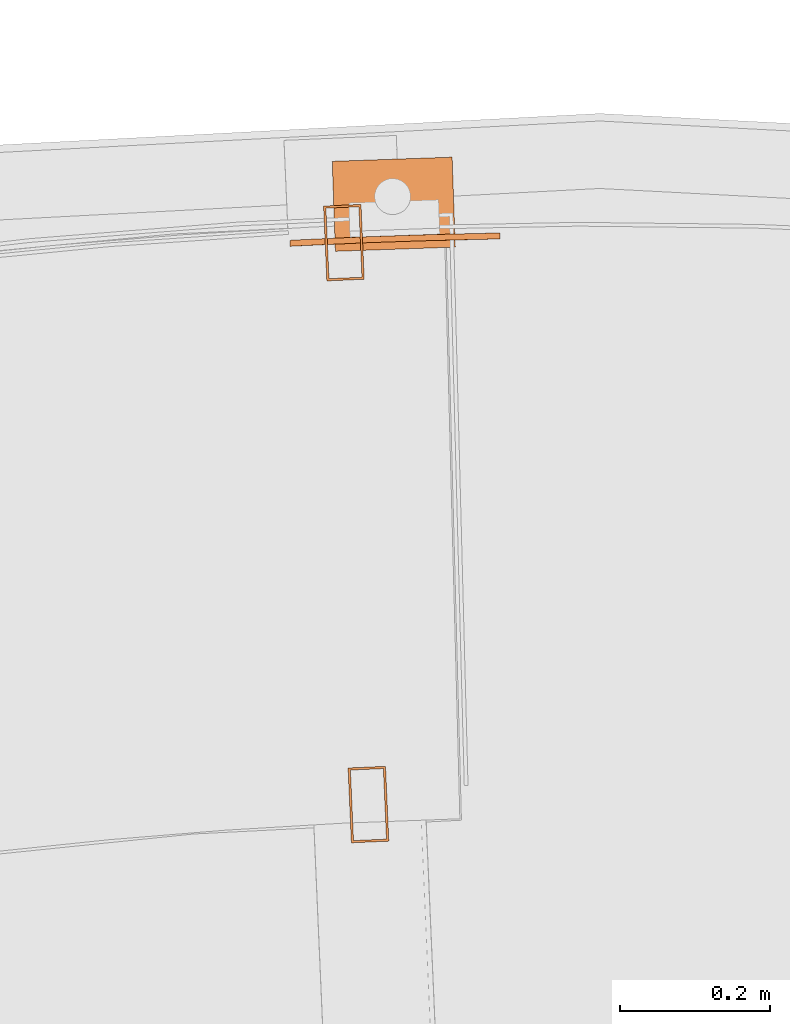
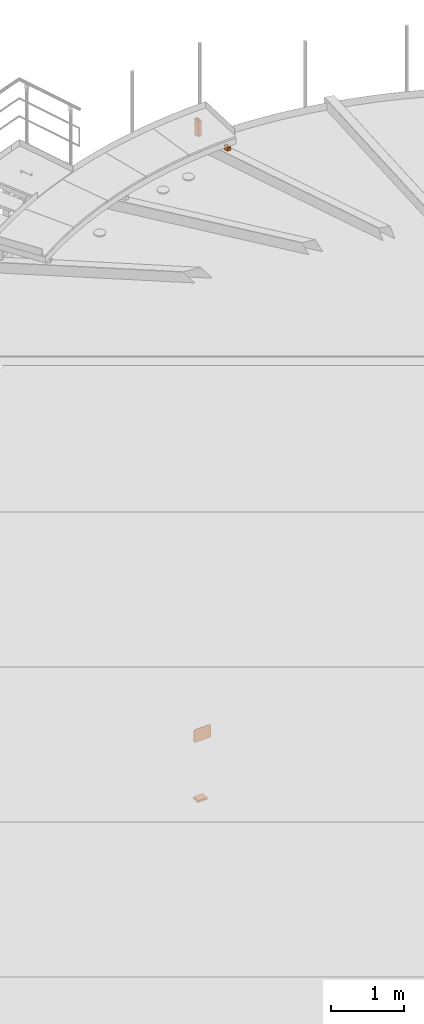
# One storey, part 92 of 126: 4 proxies.
"""IFC2X3 building model written with IfcOpenShell, lengths in millimetres."""

from ifc_helpers import new_model, si_unit, origin, origin_with_axes, place, context, project, spatial, faceted_brep, material, element, save


model = new_model("IFC2X3")

# Units and contexts
context_of_model_1 = context(None, 3, precision=0.1, world=origin())
context_of_model_2 = context(None, 3, precision=0.1, world=origin())
ifc_project = project(units=[si_unit("LENGTHUNIT", "METRE", prefix="MILLI"), si_unit("AREAUNIT", "SQUARE_METRE", prefix="CENTI"), si_unit("VOLUMEUNIT", "CUBIC_METRE", prefix="CENTI"), si_unit("MASSUNIT", "GRAM", prefix="KILO")], contexts=[context_of_model_1, context_of_model_2])

# Site, building, storey
site_placement = place(None, origin_with_axes())
site = spatial("IfcSite", under=ifc_project, at=site_placement, CompositionType="ELEMENT")
building_placement = place(site_placement, origin_with_axes())
building = spatial("IfcBuilding", under=site, at=building_placement, CompositionType="ELEMENT")
storey_placement = place(building_placement, origin_with_axes())
storey = spatial("IfcBuildingStorey", under=building, at=storey_placement, CompositionType="ELEMENT")

# Proxies
ifc_material = material(Name="STAHL")
proxy_1_placement = place(storey_placement, origin_with_axes())
element("IfcBuildingElementProxy", 1, at=proxy_1_placement, inside=storey, material=ifc_material, Name="profile", context=context_of_model_2, shape_type="Brep", body=[
    faceted_brep([(7859.1, 15822.4, 704.8), (7863.4, 15822.5, 701.2), (7863.2, 15830.5, 701.2), (7858.5, 15830.4, 705.0), (7854.1, 15822.3, 707.5), (7853.0, 15830.3, 707.9), (7848.1, 15822.2, 709.4), (7847.5, 15830.2, 709.5), (7616.6, 15814.1, 709.5), (7622.2, 15814.4, 710.0), (7695.5, 15817.7, 710.0), (7768.8, 15820.2, 710.0), (7842.1, 15822.1, 710.0), (7842.0, 15830.1, 710.0), (7768.6, 15828.2, 710.0), (7695.1, 15825.7, 710.0), (7621.7, 15822.4, 710.0), (7615.8, 15822.1, 709.4), (7597.4, 15813.2, 696.9), (7601.0, 15813.3, 701.2), (7600.6, 15821.3, 701.2), (7596.8, 15821.1, 696.5), (7594.7, 15813.0, 691.9), (7593.9, 15821.0, 691.0), (7592.8, 15812.9, 686.0), (7592.3, 15820.9, 685.5), (7592.2, 15812.9, 680.0), (7591.8, 15820.9, 680.0), (7591.8, 15820.9, 520.0), (7592.4, 15820.9, 514.0), (7592.7, 15812.9, 514.5), (7592.2, 15812.9, 520.0), (7858.9, 15830.4, 495.2), (7863.2, 15830.5, 498.8), (7863.4, 15822.5, 498.8), (7858.7, 15822.4, 495.0), (7853.9, 15830.3, 492.5), (7853.2, 15822.3, 492.1), (7848.0, 15830.2, 490.6), (7847.7, 15822.2, 490.5), (7616.2, 15814.1, 490.6), (7616.2, 15822.1, 490.5), (7621.7, 15822.4, 490.0), (7695.1, 15825.7, 490.0), (7768.6, 15828.2, 490.0), (7842.0, 15830.1, 490.0), (7842.1, 15822.1, 490.0), (7768.8, 15820.2, 490.0), (7695.5, 15817.7, 490.0), (7622.2, 15814.4, 490.0), (7597.0, 15821.1, 503.1), (7600.6, 15821.3, 498.8), (7601.0, 15813.3, 498.8), (7597.2, 15813.1, 503.5), (7594.3, 15821.0, 508.1), (7594.3, 15813.0, 509.0), (7610.7, 15821.9, 492.1), (7610.3, 15813.8, 492.5), (7605.2, 15821.6, 495.0), (7605.3, 15813.6, 495.2), (7871.5, 15822.7, 514.0), (7871.5, 15830.7, 514.5), (7872.0, 15830.7, 520.0), (7872.0, 15830.7, 680.0), (7871.4, 15830.6, 686.0), (7871.6, 15822.7, 685.5), (7872.1, 15822.7, 680.0), (7872.1, 15822.7, 520.0), (7869.9, 15830.6, 509.0), (7869.7, 15822.6, 508.1), (7867.0, 15830.6, 503.5), (7866.9, 15822.6, 503.1), (7611.1, 15813.9, 707.9), (7609.8, 15821.8, 707.5), (7605.6, 15813.6, 705.0), (7604.8, 15821.6, 704.8), (7870.0, 15822.6, 691.0), (7869.5, 15830.6, 691.9), (7867.2, 15822.6, 696.5), (7866.8, 15830.6, 696.9)], [[[0, 1, 2, 3]], [[4, 0, 3, 5]], [[6, 4, 5, 7]], [[8, 9, 10, 11, 12, 6, 7, 13, 14, 15, 16, 17]], [[18, 19, 20, 21]], [[22, 18, 21, 23]], [[24, 22, 23, 25]], [[26, 24, 25, 27, 28, 29, 30, 31]], [[32, 33, 34, 35]], [[36, 32, 35, 37]], [[38, 36, 37, 39]], [[40, 41, 42, 43, 44, 45, 38, 39, 46, 47, 48, 49]], [[50, 51, 52, 53]], [[54, 50, 53, 55]], [[29, 54, 55, 30]], [[56, 41, 40, 57]], [[58, 56, 57, 59]], [[51, 58, 59, 52]], [[60, 61, 62, 63, 64, 65, 66, 67]], [[68, 61, 60, 69]], [[70, 68, 69, 71]], [[33, 70, 71, 34]], [[72, 8, 17, 73]], [[74, 72, 73, 75]], [[19, 74, 75, 20]], [[76, 65, 64, 77]], [[78, 76, 77, 79]], [[1, 78, 79, 2]], [[26, 31, 30, 55, 53, 52, 59, 57, 40, 49, 48, 47, 46, 39, 37, 35, 34, 71, 69, 60, 67, 66, 65, 76, 78, 1, 0, 4, 6, 12, 11, 10, 9, 8, 72, 74, 19, 18, 22, 24]], [[28, 27, 25, 23, 21, 20, 75, 73, 17, 16, 15, 14, 13, 7, 5, 3, 2, 79, 77, 64, 63, 62, 61, 68, 70, 33, 32, 36, 38, 45, 44, 43, 42, 41, 56, 58, 51, 50, 54, 29]]]),
])
proxy_2_placement = place(storey_placement, origin_with_axes())
element("IfcBuildingElementProxy", 2, at=proxy_2_placement, inside=storey, material=ifc_material, Name="profile", context=context_of_model_2, shape_type="Brep", body=[
    faceted_brep([(7652.5, 15806.2, -530.0), (7648.3, 15926.2, -530.0), (7808.2, 15931.8, -530.0), (7812.4, 15811.8, -530.0), (7648.3, 15926.2, -500.0), (7808.2, 15931.8, -500.0), (7652.5, 15806.2, -500.0), (7812.4, 15811.8, -500.0)], [[[0, 1, 2, 3]], [[1, 4, 5, 2]], [[4, 6, 7, 5]], [[6, 0, 3, 7]], [[1, 0, 6, 4]], [[7, 3, 2, 5]]]),
])
proxy_3_placement = place(storey_placement, origin_with_axes())
element("IfcBuildingElementProxy", 3, at=proxy_3_placement, inside=storey, material=ifc_material, Name="profile", context=context_of_model_2, shape_type="Brep", body=[
    faceted_brep([(7669.4, 15117.3, 10873.4), (7673.8, 15017.4, 10900.2), (7673.8, 15017.4, 10955.2), (7669.4, 15117.3, 10955.2), (7723.8, 15019.6, 10900.2), (7723.8, 15019.6, 10955.2), (7719.4, 15119.5, 10873.4), (7719.4, 15119.5, 10955.2), (7676.7, 15020.5, 10899.4), (7672.6, 15114.4, 10874.2), (7672.6, 15114.4, 10955.2), (7676.7, 15020.5, 10955.2), (7716.5, 15116.4, 10874.2), (7716.5, 15116.4, 10955.2), (7720.6, 15022.4, 10899.4), (7720.6, 15022.4, 10955.2)], [[[0, 1, 2, 3]], [[1, 4, 5, 2]], [[4, 6, 7, 5]], [[6, 0, 3, 7]], [[8, 9, 10, 11]], [[9, 12, 13, 10]], [[12, 14, 15, 13]], [[14, 8, 11, 15]], [[1, 0, 6, 4], [9, 8, 14, 12]], [[2, 5, 7, 3], [15, 11, 10, 13]]]),
])
proxy_4_placement = place(storey_placement, origin_with_axes())
element("IfcBuildingElementProxy", 4, at=proxy_4_placement, inside=storey, material=ifc_material, Name="profile", context=context_of_model_2, shape_type="Brep", body=[
    faceted_brep([(7636.7, 15866.6, 10673.4), (7641.1, 15766.7, 10700.2), (7641.1, 15766.7, 10955.2), (7636.7, 15866.6, 10955.2), (7691.0, 15768.9, 10700.2), (7691.0, 15768.9, 10955.2), (7686.7, 15868.8, 10673.4), (7686.7, 15868.8, 10955.2), (7644.0, 15769.8, 10699.4), (7639.9, 15863.7, 10674.2), (7639.9, 15863.7, 10955.2), (7644.0, 15769.8, 10955.2), (7683.8, 15865.6, 10674.2), (7683.8, 15865.6, 10955.2), (7687.9, 15771.7, 10699.4), (7687.9, 15771.7, 10955.2)], [[[0, 1, 2, 3]], [[1, 4, 5, 2]], [[4, 6, 7, 5]], [[6, 0, 3, 7]], [[8, 9, 10, 11]], [[9, 12, 13, 10]], [[12, 14, 15, 13]], [[14, 8, 11, 15]], [[1, 0, 6, 4], [9, 8, 14, 12]], [[2, 5, 7, 3], [15, 11, 10, 13]]]),
])

save(model, "model.ifc")
